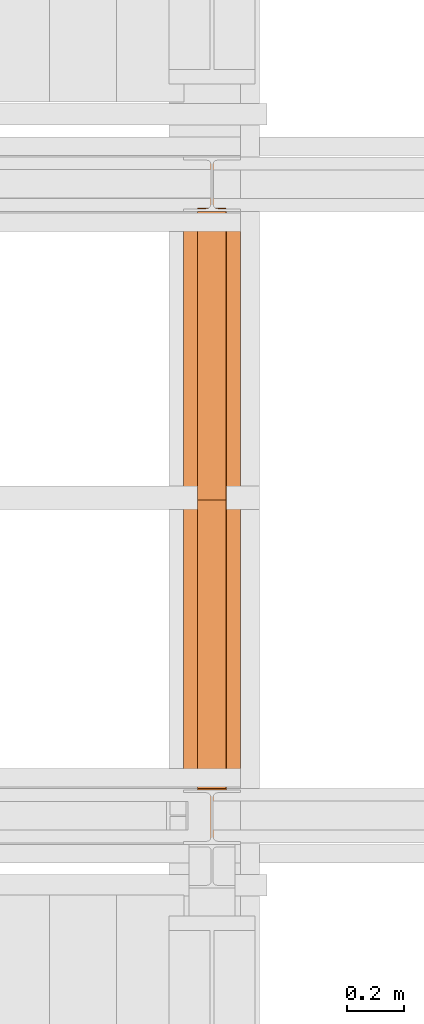
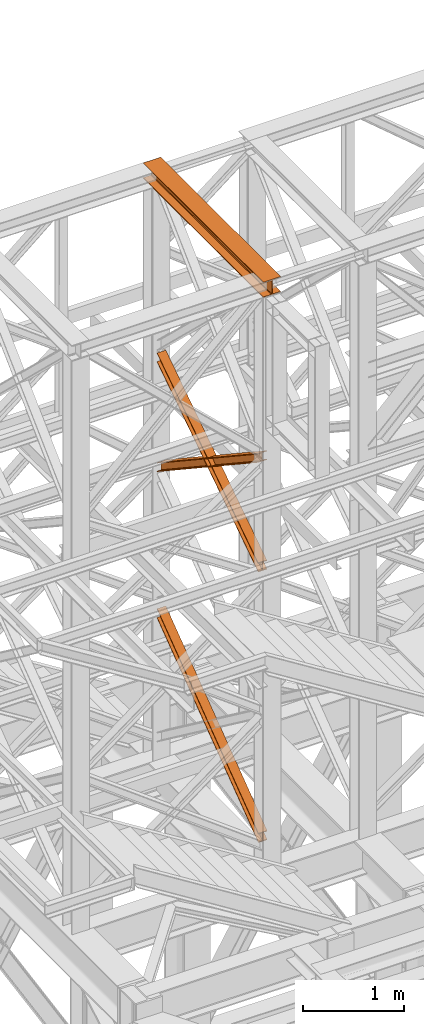
# One storey, part 99 of 208: 4 proxies.
"""IFC2X3 building model written with IfcOpenShell, lengths in millimetres."""

from ifc_helpers import new_model, entity, si_unit, converted_unit, frame, origin, origin_with_axes, place, context, subcontext, project, spatial, faceted_brep, element, save


model = new_model("IFC2X3")

# Units and contexts
model_context = context("Model", 3, precision=1e-05, world=origin())
plan_context = context("Plan", 3, precision=1e-05, world=origin())
body_context = subcontext(model_context, "Body", "Model", "MODEL_VIEW")
ifc_project = project(units=[si_unit("LENGTHUNIT", "METRE", prefix="MILLI"), converted_unit("PLANEANGLEUNIT", "DEGREE", entity("IfcPlaneAngleMeasure", 0.0174532925199433), si_unit("PLANEANGLEUNIT", "RADIAN"), dimensions=[0, 0, 0, 0, 0, 0, 0]), si_unit("AREAUNIT", "SQUARE_METRE"), si_unit("VOLUMEUNIT", "CUBIC_METRE")], contexts=[model_context, plan_context])

# Building, storey
building_placement = place(None, origin())
building = spatial("IfcBuilding", under=ifc_project, at=building_placement, CompositionType="COMPLEX")
storey_placement = place(building_placement, origin_with_axes())
storey = spatial("IfcBuildingStorey", under=building, at=storey_placement, Name="Geschoss", CompositionType="ELEMENT")

# Proxies
proxy_1_placement = place(storey_placement, frame((-1206.745032961455, -16057.57439657637, 12249.99005869381), z_axis=(0.0, 0.0, 1.0), x_axis=(1.0, 0.0, 0.0)))
element("IfcBuildingElementProxy", 1, at=proxy_1_placement, inside=storey, context=body_context, shape_type="Brep", body=[
    faceted_brep([(0.009999999999990905, 2390.010012516976, 0.01000000000021828), (200.0100029802322, 2390.010012516976, 0.01000000000021828), (200.0100029802322, 2390.010012516976, 10.00999791383765), (121.2600035762787, 2390.010012516976, 10.01000536441825), (111.9441915473342, 2390.010012516976, 11.87455041170142), (105.1245498640835, 2390.010012516976, 18.69419349193595), (103.2600015571713, 2390.010012516976, 28.01000458955787), (103.2600015571713, 2390.010012516976, 162.0100153779986), (105.1245498640835, 2390.010012516976, 171.3258264756205), (111.9441915473342, 2390.010012516976, 178.145469555855), (121.2600035762787, 2390.010012516976, 180.0100146031382), (200.0100029802322, 2390.010012516976, 180.0100146031382), (200.0100029802322, 2390.010012516976, 190.0100125169756), (0.009999999999990905, 2390.010012516976, 190.0100125169756), (0.009999999999990905, 2390.010012516976, 180.0100146031382), (78.75999940395354, 2390.010012516976, 180.0100146031382), (88.07581143289804, 2390.010012516976, 178.145469555855), (94.8954531161487, 2390.010012516976, 171.3258264756205), (96.76000142306088, 2390.010012516976, 162.0100153779986), (96.76000142306088, 2390.010012516976, 28.01000458955787), (94.8954531161487, 2390.010012516976, 18.69419349193595), (88.07581143289804, 2390.010012516976, 11.87455041170142), (78.75999940395354, 2390.010012516976, 10.01000536441825), (0.009999999999990905, 2390.010012516976, 10.00999791383765), (200.0100029802322, 2390.010012516976, 0.01000000000021828), (0.009999999999990905, 2390.010012516976, 0.01000000000021828), (0.01000000000180989, 0.00999999999839929, 0.01000000000021828), (200.0100029802341, 0.00999999999839929, 0.01000000000021828), (200.0100029802322, 2390.010012516976, 10.00999791383765), (200.0100029802322, 2390.010012516976, 0.01000000000021828), (200.0100029802341, 0.00999999999839929, 0.01000000000021828), (200.0100029802341, 0.00999999999839929, 10.00999791383765), (121.2600035762787, 2390.010012516976, 10.01000536441825), (200.0100029802322, 2390.010012516976, 10.00999791383765), (200.0100029802341, 0.00999999999839929, 10.00999791383765), (121.2600035762805, 0.00999999999839929, 10.01000536441825), (111.9441915473342, 2390.010012516976, 11.87455041170142), (121.2600035762787, 2390.010012516976, 10.01000536441825), (121.2600035762805, 0.00999999999839929, 10.01000536441825), (111.944191547336, 0.00999999999839929, 11.87455041170142), (105.1245498640835, 2390.010012516976, 18.69419349193595), (111.9441915473342, 2390.010012516976, 11.87455041170142), (111.944191547336, 0.00999999999839929, 11.87455041170142), (105.1245498640853, 0.00999999999839929, 18.69419349193595), (103.2600015571713, 2390.010012516976, 28.01000458955787), (105.1245498640835, 2390.010012516976, 18.69419349193595), (105.1245498640853, 0.00999999999839929, 18.69419349193595), (103.2600015571732, 0.00999999999839929, 28.01000458955787), (103.2600015571713, 2390.010012516976, 162.0100153779986), (103.2600015571713, 2390.010012516976, 28.01000458955787), (103.2600015571732, 0.00999999999839929, 28.01000458955787), (103.2600015571732, 0.00999999999839929, 162.0100153779986), (105.1245498640835, 2390.010012516976, 171.3258264756205), (103.2600015571713, 2390.010012516976, 162.0100153779986), (103.2600015571732, 0.00999999999839929, 162.0100153779986), (105.1245498640853, 0.00999999999839929, 171.3258264756205), (111.9441915473342, 2390.010012516976, 178.145469555855), (105.1245498640835, 2390.010012516976, 171.3258264756205), (105.1245498640853, 0.00999999999839929, 171.3258264756205), (111.944191547336, 0.00999999999839929, 178.145469555855), (121.2600035762787, 2390.010012516976, 180.0100146031382), (111.9441915473342, 2390.010012516976, 178.145469555855), (111.944191547336, 0.00999999999839929, 178.145469555855), (121.2600035762805, 0.00999999999839929, 180.0100146031382), (200.0100029802322, 2390.010012516976, 180.0100146031382), (121.2600035762787, 2390.010012516976, 180.0100146031382), (121.2600035762805, 0.00999999999839929, 180.0100146031382), (200.0100029802341, 0.00999999999839929, 180.0100146031382), (200.0100029802322, 2390.010012516976, 190.0100125169756), (200.0100029802322, 2390.010012516976, 180.0100146031382), (200.0100029802341, 0.00999999999839929, 180.0100146031382), (200.0100029802341, 0.00999999999839929, 190.0100125169756), (0.009999999999990905, 2390.010012516976, 190.0100125169756), (200.0100029802322, 2390.010012516976, 190.0100125169756), (200.0100029802341, 0.00999999999839929, 190.0100125169756), (0.01000000000180989, 0.00999999999839929, 190.0100125169756), (0.009999999999990905, 2390.010012516976, 180.0100146031382), (0.009999999999990905, 2390.010012516976, 190.0100125169756), (0.01000000000180989, 0.00999999999839929, 190.0100125169756), (0.01000000000180989, 0.00999999999839929, 180.0100146031382), (78.75999940395354, 2390.010012516976, 180.0100146031382), (0.009999999999990905, 2390.010012516976, 180.0100146031382), (0.01000000000180989, 0.00999999999839929, 180.0100146031382), (78.75999940395536, 0.00999999999839929, 180.0100146031382), (88.07581143289804, 2390.010012516976, 178.145469555855), (78.75999940395354, 2390.010012516976, 180.0100146031382), (78.75999940395536, 0.00999999999839929, 180.0100146031382), (88.07581143289985, 0.00999999999839929, 178.145469555855), (94.8954531161487, 2390.010012516976, 171.3258264756205), (88.07581143289804, 2390.010012516976, 178.145469555855), (88.07581143289985, 0.00999999999839929, 178.145469555855), (94.89545311615052, 0.00999999999839929, 171.3258264756205), (96.76000142306088, 2390.010012516976, 162.0100153779986), (94.8954531161487, 2390.010012516976, 171.3258264756205), (94.89545311615052, 0.00999999999839929, 171.3258264756205), (96.7600014230627, 0.00999999999839929, 162.0100153779986), (96.76000142306088, 2390.010012516976, 28.01000458955787), (96.76000142306088, 2390.010012516976, 162.0100153779986), (96.7600014230627, 0.00999999999839929, 162.0100153779986), (96.7600014230627, 0.00999999999839929, 28.01000458955787), (94.8954531161487, 2390.010012516976, 18.69419349193595), (96.76000142306088, 2390.010012516976, 28.01000458955787), (96.7600014230627, 0.00999999999839929, 28.01000458955787), (94.89545311615052, 0.00999999999839929, 18.69419349193595), (88.07581143289804, 2390.010012516976, 11.87455041170142), (94.8954531161487, 2390.010012516976, 18.69419349193595), (94.89545311615052, 0.00999999999839929, 18.69419349193595), (88.07581143289985, 0.00999999999839929, 11.87455041170142), (78.75999940395354, 2390.010012516976, 10.01000536441825), (88.07581143289804, 2390.010012516976, 11.87455041170142), (88.07581143289985, 0.00999999999839929, 11.87455041170142), (78.75999940395536, 0.00999999999839929, 10.01000536441825), (0.009999999999990905, 2390.010012516976, 10.00999791383765), (78.75999940395354, 2390.010012516976, 10.01000536441825), (78.75999940395536, 0.00999999999839929, 10.01000536441825), (0.01000000000180989, 0.00999999999839929, 10.00999791383765), (0.009999999999990905, 2390.010012516976, 0.01000000000021828), (0.009999999999990905, 2390.010012516976, 10.00999791383765), (0.01000000000180989, 0.00999999999839929, 10.00999791383765), (0.01000000000180989, 0.00999999999839929, 0.01000000000021828), (0.01000000000180989, 0.00999999999839929, 0.01000000000021828), (0.01000000000180989, 0.00999999999839929, 10.00999791383765), (78.75999940395536, 0.00999999999839929, 10.01000536441825), (88.07581143289985, 0.00999999999839929, 11.87455041170142), (94.89545311615052, 0.00999999999839929, 18.69419349193595), (96.7600014230627, 0.00999999999839929, 28.01000458955787), (96.7600014230627, 0.00999999999839929, 162.0100153779986), (94.89545311615052, 0.00999999999839929, 171.3258264756205), (88.07581143289985, 0.00999999999839929, 178.145469555855), (78.75999940395536, 0.00999999999839929, 180.0100146031382), (0.01000000000180989, 0.00999999999839929, 180.0100146031382), (0.01000000000180989, 0.00999999999839929, 190.0100125169756), (200.0100029802341, 0.00999999999839929, 190.0100125169756), (200.0100029802341, 0.00999999999839929, 180.0100146031382), (121.2600035762805, 0.00999999999839929, 180.0100146031382), (111.944191547336, 0.00999999999839929, 178.145469555855), (105.1245498640853, 0.00999999999839929, 171.3258264756205), (103.2600015571732, 0.00999999999839929, 162.0100153779986), (103.2600015571732, 0.00999999999839929, 28.01000458955787), (105.1245498640853, 0.00999999999839929, 18.69419349193595), (111.944191547336, 0.00999999999839929, 11.87455041170142), (121.2600035762805, 0.00999999999839929, 10.01000536441825), (200.0100029802341, 0.00999999999839929, 10.00999791383765), (200.0100029802341, 0.00999999999839929, 0.01000000000021828)], [[[0, 1, 2, 3, 4, 5, 6, 7, 8, 9, 10, 11, 12, 13, 14, 15, 16, 17, 18, 19, 20, 21, 22, 23]], [[24, 25, 26, 27]], [[28, 29, 30, 31]], [[32, 33, 34, 35]], [[36, 37, 38, 39]], [[40, 41, 42, 43]], [[44, 45, 46, 47]], [[48, 49, 50, 51]], [[52, 53, 54, 55]], [[56, 57, 58, 59]], [[60, 61, 62, 63]], [[64, 65, 66, 67]], [[68, 69, 70, 71]], [[72, 73, 74, 75]], [[76, 77, 78, 79]], [[80, 81, 82, 83]], [[84, 85, 86, 87]], [[88, 89, 90, 91]], [[92, 93, 94, 95]], [[96, 97, 98, 99]], [[100, 101, 102, 103]], [[104, 105, 106, 107]], [[108, 109, 110, 111]], [[112, 113, 114, 115]], [[116, 117, 118, 119]], [[120, 121, 122, 123, 124, 125, 126, 127, 128, 129, 130, 131, 132, 133, 134, 135, 136, 137, 138, 139, 140, 141, 142, 143]]], orient=[[False], [False], [False], [False], [False], [False], [False], [False], [False], [False], [False], [False], [False], [False], [False], [False], [False], [False], [False], [False], [False], [False], [False], [False], [False], [False]]),
])
proxy_2_placement = place(storey_placement, frame((-1157.29171440991, -15867.5743840594, 8785.68637815495), z_axis=(0.0, 0.0, 1.0), x_axis=(1.0, 0.0, 0.0)))
element("IfcBuildingElementProxy", 2, at=proxy_2_placement, inside=storey, context=body_context, shape_type="Brep", body=[
    faceted_brep([(100.0233329519012, 2010.009987483023, 1330.225167941017), (100.1729351296906, 0.00999999999839929, 0.02100513656660041), (100.1718996660054, 0.00999999999839929, 9.435622162609434), (100.022296860672, 2010.009987483023, 1339.639782821612), (0.02333355746827692, 2010.009987483023, 1330.214162804454), (0.1729357352558054, 0.00999999999839929, 0.01000000000021828), (100.1729351296906, 0.00999999999839929, 0.02100513656660041), (100.0233329519012, 2010.009987483023, 1330.225167941017), (0.02229746624084328, 2010.009987483023, 1339.628777685057), (0.171900271570621, 0.00999999999839929, 9.424617026043052), (0.1729357352558054, 0.00999999999839929, 0.01000000000021828), (0.02333355746827692, 2010.009987483023, 1330.214162804454), (47.52229717859495, 2010.009987483023, 1339.634005124923), (47.67189998392655, 0.00999999999839929, 9.429844465905262), (0.171900271570621, 0.00999999999839929, 9.424617026043052), (0.02229746624084328, 2010.009987483023, 1339.628777685057), (47.51193626628788, 2010.009987483023, 1433.780153930935), (47.6615453605898, 0.00999999999839929, 103.5760147725105), (47.67189998392655, 0.00999999999839929, 9.429844465905262), (47.52229717859495, 2010.009987483023, 1339.634005124923), (0.01106478197630167, 2021.979642245309, 1441.696427017001), (0.01120823570613538, 2020.00998539686, 1440.39291091142), (29.30668085241064, 2020.00998539686, 1440.396134918205), (38.62249288135513, 2021.874530444144, 1441.631113415808), (38.7276046609893, 2021.979642245309, 1441.70068782511), (47.51193626628788, 2010.009987483023, 1433.780153930935), (0.01193655393194604, 2010.009987483023, 1433.774926491073), (0.1615456482338686, 0.00999999999839929, 103.5707873326446), (47.6615453605898, 0.00999999999839929, 103.5760147725105), (0.009999999999990905, 2022.373573614999, 1451.371745118717), (0.01017214447506376, 2020.00998539686, 1449.807525792019), (0.01120823570613538, 2020.00998539686, 1440.39291091142), (0.01106478197630167, 2021.979642245309, 1441.696427017001), (0.01193655393194604, 2010.009987483023, 1433.774926491073), (0.0109004627026934, 2010.009987483023, 1443.189541371672), (0.1605101872535215, 0.00999999999839929, 112.9854043679352), (0.1615456482338686, 0.00999999999839929, 103.5707873326446), (100.0099993944384, 2022.373573614997, 1451.382750255283), (100.0101715389135, 2020.00998539686, 1449.818530928586), (71.80668502473577, 2020.00998539686, 1449.815427096359), (62.49087299579128, 2021.874530444144, 1451.048355158282), (61.99182992716465, 2022.373573614999, 1451.378566303787), (0.0109004627026934, 2010.009987483023, 1443.189541371672), (100.0108998571393, 2010.009987483023, 1443.200546508238), (100.1605095816919, 0.00999999999839929, 112.9964095044979), (0.1605101872535215, 0.00999999999839929, 112.9854043679352), (0.01017214447506376, 2020.00998539686, 1449.807525792019), (0.009999999999990905, 2022.373573614999, 1451.371745118717), (39.12153594997994, 2022.373573614999, 1451.376049396686), (38.62249288135513, 2021.874530444144, 1451.045728410436), (29.30668085241064, 2020.00998539686, 1449.810749912833), (100.0110641764129, 2021.979642245307, 1441.707432153557), (100.0112076301409, 2020.00998539686, 1440.403916047975), (100.0101715389135, 2020.00998539686, 1449.818530928586), (100.0099993944384, 2022.373573614997, 1451.382750255283), (100.0108998571393, 2010.009987483023, 1443.200546508238), (100.0119359483704, 2010.009987483023, 1433.785931627628), (100.1615450426668, 0.00999999999839929, 103.5817924692037), (100.1605095816919, 0.00999999999839929, 112.9964095044979), (52.5119362360108, 2010.009987483023, 1433.780704187766), (52.66154533031272, 0.00999999999839929, 103.5765650293379), (100.1615450426668, 0.00999999999839929, 103.5817924692037), (100.0119359483704, 2010.009987483023, 1433.785931627628), (71.80668502473577, 2020.00998539686, 1440.400812101727), (100.0112076301409, 2020.00998539686, 1440.403916047975), (100.0110641764129, 2021.979642245307, 1441.707432153557), (62.38576121615711, 2021.979642245309, 1441.703291437565), (62.49087299579128, 2021.874530444144, 1441.63374016365), (52.52229714831424, 2010.009987483023, 1339.63455538175), (52.67189995364765, 0.00999999999839929, 9.43039472273631), (52.66154533031272, 0.00999999999839929, 103.5765650293379), (52.5119362360108, 2010.009987483023, 1433.780704187766), (100.022296860672, 2010.009987483023, 1339.639782821612), (100.1718996660054, 0.00999999999839929, 9.435622162609434), (52.67189995364765, 0.00999999999839929, 9.43039472273631), (52.52229714831424, 2010.009987483023, 1339.63455538175), (62.38576121615711, 2021.979642245309, 1441.703291437565), (100.0110641764129, 2021.979642245307, 1441.707432153557), (100.0099993944384, 2022.373573614997, 1451.382750255283), (61.99182992716465, 2022.373573614999, 1451.378566303787), (39.12153594997994, 2022.373573614999, 1451.376049396686), (0.009999999999990905, 2022.373573614999, 1451.371745118717), (0.01106478197630167, 2021.979642245309, 1441.696427017001), (38.7276046609893, 2021.979642245309, 1441.70068782511), (62.49087299579128, 2021.874530444144, 1441.63374016365), (62.38576121615711, 2021.979642245309, 1441.703291437565), (61.99182992716465, 2022.373573614999, 1451.378566303787), (62.49087299579128, 2021.874530444144, 1451.048355158282), (62.49087299579128, 2021.874530444144, 1451.048355158282), (71.80668502473577, 2020.00998539686, 1449.815427096359), (71.80668502473577, 2020.00998539686, 1440.400812101727), (62.49087299579128, 2021.874530444144, 1441.63374016365), (71.80668502473577, 2020.00998539686, 1449.815427096359), (100.0101715389135, 2020.00998539686, 1449.818530928586), (100.0112076301409, 2020.00998539686, 1440.403916047975), (71.80668502473577, 2020.00998539686, 1440.400812101727), (100.022296860672, 2010.009987483023, 1339.639782821612), (52.52229714831424, 2010.009987483023, 1339.63455538175), (52.5119362360108, 2010.009987483023, 1433.780704187766), (100.0119359483704, 2010.009987483023, 1433.785931627628), (100.0108998571393, 2010.009987483023, 1443.200546508238), (0.0109004627026934, 2010.009987483023, 1443.189541371672), (0.01193655393194604, 2010.009987483023, 1433.774926491073), (47.51193626628788, 2010.009987483023, 1433.780153930935), (47.52229717859495, 2010.009987483023, 1339.634005124923), (0.02229746624084328, 2010.009987483023, 1339.628777685057), (0.02333355746827692, 2010.009987483023, 1330.214162804454), (100.0233329519012, 2010.009987483023, 1330.225167941017), (29.30668085241064, 2020.00998539686, 1440.396134918205), (0.01120823570613538, 2020.00998539686, 1440.39291091142), (0.01017214447506376, 2020.00998539686, 1449.807525792019), (29.30668085241064, 2020.00998539686, 1449.810749912833), (29.30668085241064, 2020.00998539686, 1449.810749912833), (38.62249288135513, 2021.874530444144, 1451.045728410436), (38.62249288135513, 2021.874530444144, 1441.631113415808), (29.30668085241064, 2020.00998539686, 1440.396134918205), (38.62249288135513, 2021.874530444144, 1451.045728410436), (39.12153594997994, 2022.373573614999, 1451.376049396686), (38.7276046609893, 2021.979642245309, 1441.70068782511), (38.62249288135513, 2021.874530444144, 1441.631113415808), (100.1729351296906, 0.00999999999839929, 0.02100513656660041), (0.1729357352558054, 0.00999999999839929, 0.01000000000021828), (0.171900271570621, 0.00999999999839929, 9.424617026043052), (47.67189998392655, 0.00999999999839929, 9.429844465905262), (47.6615453605898, 0.00999999999839929, 103.5760147725105), (0.1615456482338686, 0.00999999999839929, 103.5707873326446), (0.1605101872535215, 0.00999999999839929, 112.9854043679352), (100.1605095816919, 0.00999999999839929, 112.9964095044979), (100.1615450426668, 0.00999999999839929, 103.5817924692037), (52.66154533031272, 0.00999999999839929, 103.5765650293379), (52.67189995364765, 0.00999999999839929, 9.43039472273631), (100.1718996660054, 0.00999999999839929, 9.435622162609434)], [[[0, 1, 2, 3]], [[4, 5, 6, 7]], [[8, 9, 10, 11]], [[12, 13, 14, 15]], [[16, 17, 18, 19]], [[20, 21, 22, 23, 24]], [[25, 26, 27, 28]], [[29, 30, 31, 32]], [[33, 34, 35, 36]], [[37, 38, 39, 40, 41]], [[42, 43, 44, 45]], [[46, 47, 48, 49, 50]], [[51, 52, 53, 54]], [[55, 56, 57, 58]], [[59, 60, 61, 62]], [[63, 64, 65, 66, 67]], [[68, 69, 70, 71]], [[72, 73, 74, 75]], [[76, 77, 78, 79]], [[80, 81, 82, 83]], [[84, 85, 86, 87]], [[88, 89, 90, 91]], [[92, 93, 94, 95]], [[96, 97, 98, 99, 100, 101, 102, 103, 104, 105, 106, 107]], [[108, 109, 110, 111]], [[112, 113, 114, 115]], [[116, 117, 118, 119]], [[120, 121, 122, 123, 124, 125, 126, 127, 128, 129, 130, 131]]], orient=[[False], [False], [False], [False], [False], [False], [False], [False], [False], [False], [False], [False], [False], [False], [False], [False], [False], [False], [False], [False], [False], [False], [False], [False], [False], [False], [False], [False]]),
])
proxy_3_placement = place(storey_placement, frame((-1157.282239092163, -15867.5743840594, 8785.050753356181), z_axis=(0.0, 0.0, 1.0), x_axis=(1.0, 0.0, 0.0)))
element("IfcBuildingElementProxy", 3, at=proxy_3_placement, inside=storey, context=body_context, shape_type="Brep", body=[
    faceted_brep([(100.0213960296203, 0.01000000000021828, 1340.168495796863), (100.1712583843325, 2010.009987483025, 9.436734304987112), (100.172293937763, 2010.009987483025, 0.02100513655932446), (100.0224320873656, 0.01000000000021828, 1330.752768748162), (100.0224320873656, 0.01000000000021828, 1330.752768748162), (100.172293937763, 2010.009987483025, 0.02100513655932446), (0.1722945433282348, 2010.009987483025, 0.01000000000021828), (0.02243269293262529, 0.01000000000021828, 1330.741763611606), (0.02243269293262529, 0.01000000000021828, 1330.741763611606), (0.1722945433282348, 2010.009987483025, 0.01000000000021828), (0.1712589898995702, 2010.009987483025, 9.425729168431644), (0.02139663518914858, 0.01000000000021828, 1340.1574906603), (0.02139663518914858, 0.01000000000021828, 1340.1574906603), (0.1712589898995702, 2010.009987483025, 9.425729168431644), (47.67125870225732, 2010.009987483025, 9.430956608297492), (47.5213963475469, 0.01000000000021828, 1340.162718100166), (47.5213963475469, 0.01000000000021828, 1340.162718100166), (47.67125870225732, 2010.009987483025, 9.430956608297492), (47.66090317872454, 2010.009987483025, 103.5882483377918), (47.51103577010122, 0.01000000000021828, 1434.319988587145), (47.51103577010122, 0.01000000000021828, 1434.319988587145), (47.66090317872454, 2010.009987483025, 103.5882483377918), (0.1609034663686089, 2010.009987483025, 103.583020897926), (0.0110360577452866, 0.01000000000021828, 1434.31476114728), (0.0110360577452866, 0.01000000000021828, 1434.31476114728), (0.1609034663686089, 2010.009987483025, 103.583020897926), (0.1598679150918088, 2010.009987483025, 112.998750075405), (0.009999999999990905, 0.01000000000021828, 1443.730488195981), (0.009999999999990905, 0.01000000000021828, 1443.730488195981), (0.1598679150918088, 2010.009987483025, 112.998750075405), (100.1598673095248, 2010.009987483025, 113.0097552119678), (100.0099993944348, 0.01000000000021828, 1443.741493332544), (100.0099993944348, 0.01000000000021828, 1443.741493332544), (100.1598673095248, 2010.009987483025, 113.0097552119678), (100.1609028608016, 2010.009987483025, 103.5940260344851), (100.0110354521783, 0.01000000000021828, 1434.325766283846), (100.0110354521783, 0.01000000000021828, 1434.325766283846), (100.1609028608016, 2010.009987483025, 103.5940260344851), (52.66090314844564, 2010.009987483025, 103.5887985946229), (52.51103573982414, 0.01000000000021828, 1434.320538843973), (52.51103573982414, 0.01000000000021828, 1434.320538843973), (52.66090314844564, 2010.009987483025, 103.5887985946229), (52.6712586719766, 2010.009987483025, 9.431506865121264), (52.521396317268, 0.01000000000021828, 1340.163268357001), (52.521396317268, 0.01000000000021828, 1340.163268357001), (52.6712586719766, 2010.009987483025, 9.431506865121264), (100.1712583843325, 2010.009987483025, 9.436734304987112), (100.0213960296203, 0.01000000000021828, 1340.168495796863), (100.0224320873656, 0.01000000000021828, 1330.752768748162), (0.02243269293262529, 0.01000000000021828, 1330.741763611606), (0.02139663518914858, 0.01000000000021828, 1340.1574906603), (47.5213963475469, 0.01000000000021828, 1340.162718100166), (47.51103577010122, 0.01000000000021828, 1434.319988587145), (0.0110360577452866, 0.01000000000021828, 1434.31476114728), (0.009999999999990905, 0.01000000000021828, 1443.730488195981), (100.0099993944348, 0.01000000000021828, 1443.741493332544), (100.0110354521783, 0.01000000000021828, 1434.325766283846), (52.51103573982414, 0.01000000000021828, 1434.320538843973), (52.521396317268, 0.01000000000021828, 1340.163268357001), (100.0213960296203, 0.01000000000021828, 1340.168495796863), (100.1712583843325, 2010.009987483025, 9.436734304987112), (52.6712586719766, 2010.009987483025, 9.431506865121264), (52.66090314844564, 2010.009987483025, 103.5887985946229), (100.1609028608016, 2010.009987483025, 103.5940260344851), (100.1598673095248, 2010.009987483025, 113.0097552119678), (0.1598679150918088, 2010.009987483025, 112.998750075405), (0.1609034663686089, 2010.009987483025, 103.583020897926), (47.66090317872454, 2010.009987483025, 103.5882483377918), (47.67125870225732, 2010.009987483025, 9.430956608297492), (0.1712589898995702, 2010.009987483025, 9.425729168431644), (0.1722945433282348, 2010.009987483025, 0.01000000000021828), (100.172293937763, 2010.009987483025, 0.02100513655932446)], [[[0, 1, 2, 3]], [[4, 5, 6, 7]], [[8, 9, 10, 11]], [[12, 13, 14, 15]], [[16, 17, 18, 19]], [[20, 21, 22, 23]], [[24, 25, 26, 27]], [[28, 29, 30, 31]], [[32, 33, 34, 35]], [[36, 37, 38, 39]], [[40, 41, 42, 43]], [[44, 45, 46, 47]], [[48, 49, 50, 51, 52, 53, 54, 55, 56, 57, 58, 59]], [[60, 61, 62, 63, 64, 65, 66, 67, 68, 69, 70, 71]]], orient=[[False], [False], [False], [False], [False], [False], [False], [False], [False], [False], [False], [False], [False], [False]]),
])
proxy_4_placement = place(storey_placement, frame((-1156.917201508901, -15873.1965123697, 5499.689768811883), z_axis=(0.0, 0.0, 1.0), x_axis=(1.0, 0.0, 0.0)))
element("IfcBuildingElementProxy", 4, at=proxy_4_placement, inside=storey, context=body_context, shape_type="Brep", body=[
    faceted_brep([(100.0229428112286, 2015.632115793322, 1505.703241650141), (100.1858455764684, 1.953628280809426, 0.02100513656296243), (100.1847800613884, 1.791659257409265, 9.702984703128095), (100.021864193164, 2015.632115793322, 1515.50632986583), (0.02294341679748868, 2015.632115793322, 1505.692236513578), (0.1858461820336288, 1.953628280809426, 0.01000000000021828), (100.1858455764684, 1.953628280809426, 0.02100513656296243), (100.0229428112286, 2015.632115793322, 1505.703241650141), (0.02186479873103053, 2015.632115793322, 1515.495324729271), (0.1847806669536567, 1.791659257407446, 9.691979566568989), (0.1858461820336288, 1.953628280809426, 0.01000000000021828), (0.02294341679748868, 2015.632115793322, 1505.692236513578), (47.52186451108332, 2015.632115793322, 1515.500552169136), (47.68478037930959, 1.791659257407446, 9.697207006434837), (0.1847806669536567, 1.791659257407446, 9.691979566568989), (0.02186479873103053, 2015.632115793322, 1515.495324729271), (47.51107833042602, 2015.632115793322, 1613.531434326045), (47.67412522851714, 0.1719690234003792, 106.517002672068), (47.68478037930959, 1.791659257407446, 9.697207006434837), (47.52186451108332, 2015.632115793322, 1515.500552169136), (0.01107861806826804, 2015.632115793322, 1613.526206886179), (0.1741255161575737, 0.1719690234003792, 106.5117752322021), (47.67412522851714, 0.1719690234003792, 106.517002672068), (47.51107833042602, 2015.632115793322, 1613.531434326045), (0.009999999999990905, 2015.632115793322, 1623.329295101868), (0.1730600010776016, 0.01000000000021828, 116.1937547987636), (0.1741255161575737, 0.1719690234003792, 106.5117752322021), (0.01107861806826804, 2015.632115793322, 1613.526206886179), (100.0099993944384, 2015.632115793322, 1623.340300238435), (100.1730593955124, 0.01000000000203727, 116.2047599353264), (0.1730600010776016, 0.01000000000021828, 116.1937547987636), (0.009999999999990905, 2015.632115793322, 1623.329295101868), (100.0110780125049, 2015.632115793322, 1613.537212022739), (100.1741249105905, 0.1719690234003792, 106.5227803687612), (100.1730593955124, 0.01000000000203727, 116.2047599353264), (100.0099993944384, 2015.632115793322, 1623.340300238435), (52.51107830014894, 2015.632115793322, 1613.531984582873), (52.67412519823643, 0.1719690234003792, 106.5175529288954), (100.1741249105905, 0.1719690234003792, 106.5227803687612), (100.0110780125049, 2015.632115793322, 1613.537212022739), (52.52186448080806, 2015.632115793322, 1515.501102425964), (52.68478034903251, 1.791659257409265, 9.697757263262247), (52.67412519823643, 0.1719690234003792, 106.5175529288954), (52.51107830014894, 2015.632115793322, 1613.531984582873), (100.021864193164, 2015.632115793322, 1515.50632986583), (100.1847800613884, 1.791659257409265, 9.702984703128095), (52.68478034903251, 1.791659257409265, 9.697757263262247), (52.52186448080806, 2015.632115793322, 1515.501102425964), (100.1858455764684, 1.953628280809426, 0.02100513656296243), (0.1858461820336288, 1.953628280809426, 0.01000000000021828), (0.1847806669536567, 1.791659257407446, 9.691979566568989), (47.68478037930959, 1.791659257407446, 9.697207006434837), (47.67412522851714, 0.1719690234003792, 106.517002672068), (0.1741255161575737, 0.1719690234003792, 106.5117752322021), (0.1730600010776016, 0.01000000000021828, 116.1937547987636), (100.1730593955124, 0.01000000000203727, 116.2047599353264), (100.1741249105905, 0.1719690234003792, 106.5227803687612), (52.67412519823643, 0.1719690234003792, 106.5175529288954), (52.68478034903251, 1.791659257409265, 9.697757263262247), (100.1847800613884, 1.791659257409265, 9.702984703128095), (100.021864193164, 2015.632115793322, 1515.50632986583), (52.52186448080806, 2015.632115793322, 1515.501102425964), (52.51107830014894, 2015.632115793322, 1613.531984582873), (100.0110780125049, 2015.632115793322, 1613.537212022739), (100.0099993944384, 2015.632115793322, 1623.340300238435), (0.009999999999990905, 2015.632115793322, 1623.329295101868), (0.01107861806826804, 2015.632115793322, 1613.526206886179), (47.51107833042602, 2015.632115793322, 1613.531434326045), (47.52186451108332, 2015.632115793322, 1515.500552169136), (0.02186479873103053, 2015.632115793322, 1515.495324729271), (0.02294341679748868, 2015.632115793322, 1505.692236513578), (100.0229428112286, 2015.632115793322, 1505.703241650141)], [[[0, 1, 2, 3]], [[4, 5, 6, 7]], [[8, 9, 10, 11]], [[12, 13, 14, 15]], [[16, 17, 18, 19]], [[20, 21, 22, 23]], [[24, 25, 26, 27]], [[28, 29, 30, 31]], [[32, 33, 34, 35]], [[36, 37, 38, 39]], [[40, 41, 42, 43]], [[44, 45, 46, 47]], [[48, 49, 50, 51, 52, 53, 54, 55, 56, 57, 58, 59]], [[60, 61, 62, 63, 64, 65, 66, 67, 68, 69, 70, 71]]], orient=[[False], [False], [False], [False], [False], [False], [False], [False], [False], [False], [False], [False], [False], [False]]),
])

save(model, "model.ifc")
